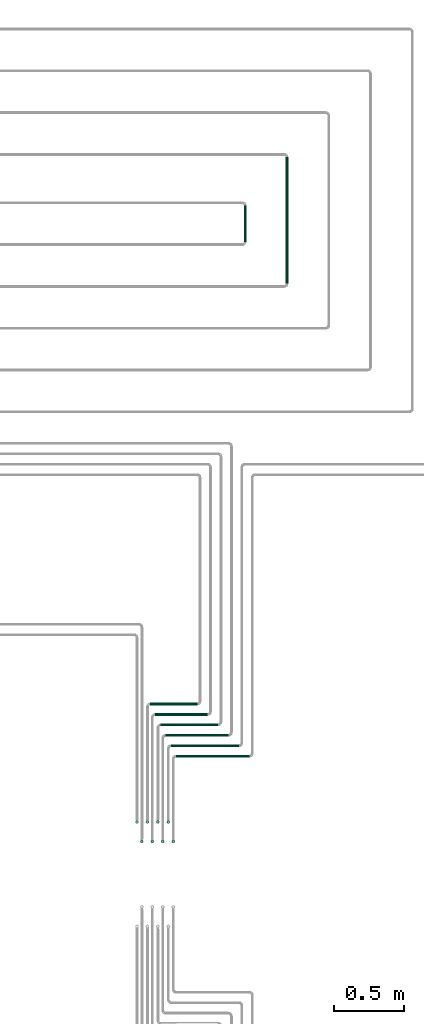
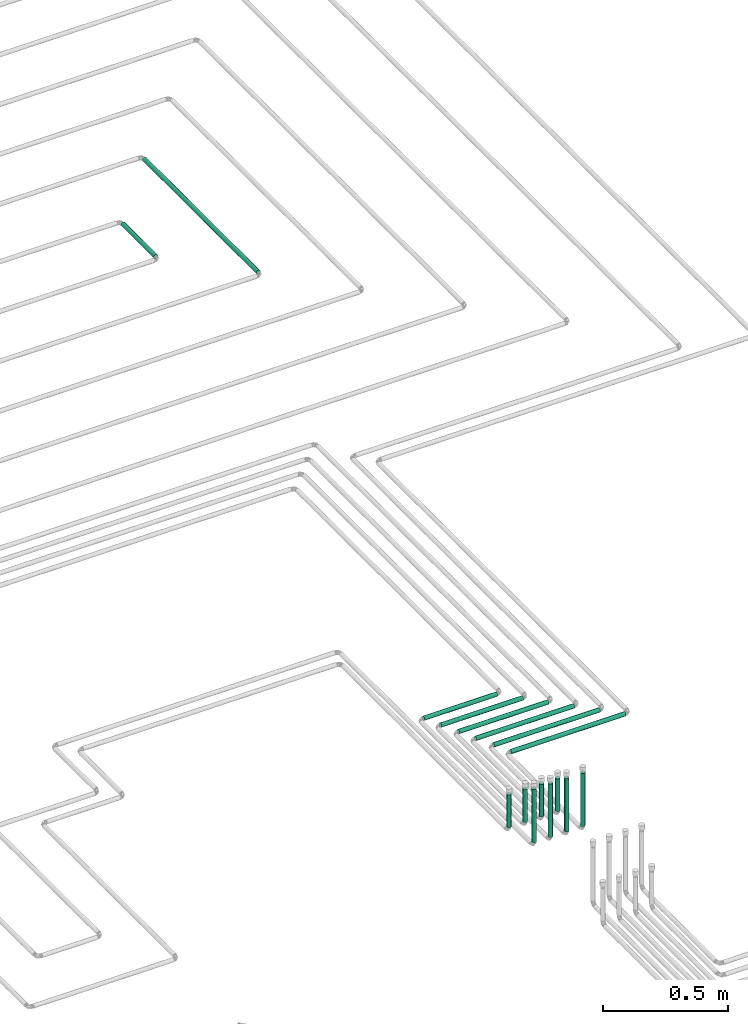
# One storey, part 6 of 12: 16 flow segments.
"""IFC2X3 building model written with IfcOpenShell, lengths in millimetres."""

import ifcopenshell
import ifcopenshell.guid

model = None  # the IFC model being written
_history = None  # IfcOwnerHistory: only IFC2X3 demands one
_inside = {}  # id of a spatial element -> (the spatial element, [elements in it])
_under = {}  # id of a project, library or spatial element -> (it, [spatial elements below it])
_declared = {}  # id of a project -> (the project, [libraries it declares])
_typed = {}  # id of a type object -> (the type object, [elements of that type])
_made_of = {}  # id of a material, layer set ... -> (it, [elements and type objects made of it])


def new_model(schema):
    """Start an empty IFC model of exactly this schema.

    Asked for "IFC4X3", IfcOpenShell would pick the latest addendum, in which some entities
    have other attributes; the version numbers below select the first issue.
    IFC2X3 requires an IfcOwnerHistory on every rooted entity: one is made here for all.
    """
    global model, _history
    if schema == "IFC4X3":
        model = ifcopenshell.file(schema_version=(4, 3, 0, 0))
    else:
        model = ifcopenshell.file(schema=schema)
    _inside.clear()
    _under.clear()
    _declared.clear()
    _typed.clear()
    _made_of.clear()
    _history = None
    if model.schema == "IFC2X3":
        org = make("IfcOrganization", Name="unknown")
        user = make(
            "IfcPersonAndOrganization",
            ThePerson=make("IfcPerson", FamilyName="unknown"),
            TheOrganization=org,
        )
        app = make(
            "IfcApplication",
            ApplicationDeveloper=org,
            Version="unknown",
            ApplicationFullName="unknown",
            ApplicationIdentifier="unknown",
        )
        _history = make(
            "IfcOwnerHistory",
            OwningUser=user,
            OwningApplication=app,
            ChangeAction="ADDED",
            CreationDate=0,
        )
    return model


def make(cls, **values):
    """One entity of the class cls with the attributes given. An attribute that is None is left unset."""
    return model.create_entity(
        cls, **{name: value for name, value in values.items() if value is not None}
    )


def entity(cls, *values):
    """Any entity or typed value of the class cls, its attributes in the order of the schema. None: left unset."""
    e = model.create_entity(cls)
    for i, value in enumerate(values):
        if value is not None:
            e[i] = value
    return e


def rooted(cls, **values):
    """An entity with a GlobalId (a new one), such as an element, a storey or a relation."""
    return make(cls, GlobalId=ifcopenshell.guid.new(), OwnerHistory=_history, **values)


def si_unit(unit_type, name, prefix=None):
    """IfcSIUnit, for example si_unit("LENGTHUNIT", "METRE", prefix="MILLI")."""
    return make("IfcSIUnit", UnitType=unit_type, Prefix=prefix, Name=name)


def converted_unit(unit_type, name, factor, base, dimensions=None, offset=None):
    """IfcConversionBasedUnit, such as the inch: factor (a typed value) times the base unit."""
    return make(
        "IfcConversionBasedUnit"
        if offset is None
        else "IfcConversionBasedUnitWithOffset",
        ConversionOffset=offset,
        Dimensions=None
        if dimensions is None
        else entity("IfcDimensionalExponents", *dimensions),
        UnitType=unit_type,
        Name=name,
        ConversionFactor=make(
            "IfcMeasureWithUnit", ValueComponent=factor, UnitComponent=base
        ),
    )


def derived_unit(unit_type, elements):
    """IfcDerivedUnit: a product of units, each with its exponent."""
    return make(
        "IfcDerivedUnit",
        Elements=[
            make("IfcDerivedUnitElement", Unit=unit, Exponent=power)
            for unit, power in elements
        ],
        UnitType=unit_type,
    )


def assignment(units):
    """IfcUnitAssignment: the units of a project."""
    return None if units is None else make("IfcUnitAssignment", Units=units)


def point(xyz):
    """IfcCartesianPoint."""
    return None if xyz is None else make("IfcCartesianPoint", Coordinates=xyz)


def direction(xyz):
    """IfcDirection."""
    return None if xyz is None else make("IfcDirection", DirectionRatios=xyz)


def frame(location, z_axis=None, x_axis=None):
    """IfcAxis2Placement3D, a coordinate frame: its origin and axes. An axis left out is left unset."""
    return make(
        "IfcAxis2Placement3D",
        Location=point(location),
        Axis=direction(z_axis),
        RefDirection=direction(x_axis),
    )


def frame_2d(location, x_axis=None):
    """IfcAxis2Placement2D, a coordinate frame in the plane: its origin and x axis."""
    return make(
        "IfcAxis2Placement2D", Location=point(location), RefDirection=direction(x_axis)
    )


def origin():
    """The frame at (0, 0, 0) with its axes left unset."""
    return frame((0.0, 0.0, 0.0))


def origin_2d_with_axis():
    """The frame at (0, 0) in the plane with the x axis (1, 0) written out."""
    return frame_2d((0.0, 0.0), x_axis=(1.0, 0.0))


def place(relative_to, where):
    """IfcLocalPlacement: puts the frame where relative to a parent placement (None: the world)."""
    return make(
        "IfcLocalPlacement", PlacementRelTo=relative_to, RelativePlacement=where
    )


def context(
    kind, dimensions, precision=None, world=None, true_north=None, identifier=None
):
    """IfcGeometricRepresentationContext, for example the 3D "Model" context."""
    return make(
        "IfcGeometricRepresentationContext",
        ContextIdentifier=identifier,
        ContextType=kind,
        CoordinateSpaceDimension=dimensions,
        Precision=precision,
        WorldCoordinateSystem=world,
        TrueNorth=true_north,
    )


def subcontext(parent, identifier, kind, view, scale=None):
    """IfcGeometricRepresentationSubContext, for example "Body" below "Model"."""
    return make(
        "IfcGeometricRepresentationSubContext",
        ContextIdentifier=identifier,
        ContextType=kind,
        ParentContext=parent,
        TargetScale=scale,
        TargetView=view,
    )


def project(units=None, contexts=None):
    """IfcProject with its units and contexts."""
    return rooted(
        "IfcProject",
        Name="project",
        RepresentationContexts=contexts,
        UnitsInContext=assignment(units),
    )


def spatial(cls, under=None, at=None, **own):
    """A site, building, storey or space (cls), placed at a placement, below another one or the project."""
    s = rooted(cls, ObjectPlacement=at, **own)
    if under is not None:
        _under.setdefault(under.id(), (under, []))[1].append(s)
    return s


def profile(cls, at=None, kind="AREA", **sizes):
    """A parametric profile (cls). Its sizes go by their IFC names, for example OverallWidth=200.0."""
    return make(cls, ProfileType=kind, Position=at, **sizes)


def circle(**sizes):
    """IfcCircleProfileDef."""
    return profile("IfcCircleProfileDef", **sizes)


def extrude(swept, where, along, depth):
    """IfcExtrudedAreaSolid: the profile swept, set in the frame where, extruded along a direction by depth."""
    return make(
        "IfcExtrudedAreaSolid",
        SweptArea=swept,
        Position=where,
        ExtrudedDirection=direction(along),
        Depth=depth,
    )


def shape(context_of_items, identifier, shape_type, items):
    """IfcShapeRepresentation: the items that make up one representation, for example the "Body"."""
    return make(
        "IfcShapeRepresentation",
        ContextOfItems=context_of_items,
        RepresentationIdentifier=identifier,
        RepresentationType=shape_type,
        Items=items,
    )


def made_of(thing, what):
    """Note that an element or type object is made of a material, layer set ...; save() writes the relation."""
    if what is not None:
        _made_of.setdefault(what.id(), (what, []))[1].append(thing)
    return thing


def type_object(cls, material=None, **own):
    """A type object (cls), such as IfcWallType, which elements share."""
    return made_of(rooted(cls, **own), material)


def element(
    cls,
    number,
    at=None,
    inside=None,
    cuts=None,
    type_object=None,
    material=None,
    context=None,
    identifier="Body",
    shape_type=None,
    held_by="IfcProductDefinitionShape",
    body=None,
    shapes=None,
    **own,
):
    """One element of the class cls, such as IfcWall. Its Tag is "e" and its number.

    at: its placement. inside: the storey or other place that contains it. cuts: it is an
    opening in that element (IfcRelVoidsElement). A single representation is given by context,
    identifier, shape_type and body (its items); several are given by shapes. held_by: the class
    of the entity that holds the representations. save() writes the other relations.
    """
    e = rooted(cls, Tag="e%d" % number, ObjectPlacement=at, **own)
    if body is not None:
        shapes = [shape(context, identifier, shape_type, body)]
    if shapes is not None:
        e.Representation = make(held_by, Representations=shapes)
    if inside is not None:
        _inside.setdefault(inside.id(), (inside, []))[1].append(e)
    if cuts is not None:
        rooted(
            "IfcRelVoidsElement", RelatingBuildingElement=cuts, RelatedOpeningElement=e
        )
    if type_object is not None:
        _typed.setdefault(type_object.id(), (type_object, []))[1].append(e)
    return made_of(e, material)


def aggregate(whole, parts):
    """IfcRelAggregates: a whole, such as a stair, and the parts it consists of."""
    return rooted("IfcRelAggregates", RelatingObject=whole, RelatedObjects=parts)


def save(model, path):
    """Write the relations noted so far, then the file.

    IfcRelAggregates (storeys below a building ...), IfcRelContainedInSpatialStructure (elements
    in a storey), IfcRelDefinesByType, IfcRelAssociatesMaterial and IfcRelDeclares: one each for
    every whole, place, type object, material and project.
    """
    for whole, parts in _under.values():
        aggregate(whole, parts)
    for where, things in _inside.values():
        rooted(
            "IfcRelContainedInSpatialStructure",
            RelatedElements=things,
            RelatingStructure=where,
        )
    for kind, things in _typed.values():
        rooted("IfcRelDefinesByType", RelatedObjects=things, RelatingType=kind)
    for what, things in _made_of.values():
        rooted("IfcRelAssociatesMaterial", RelatedObjects=things, RelatingMaterial=what)
    for by, libraries in _declared.values():
        rooted("IfcRelDeclares", RelatingContext=by, RelatedDefinitions=libraries)
    model.write(path)


model = new_model("IFC2X3")

# Units and contexts
model_context = context("Model", 3, precision=0.01, world=origin(), true_north=direction((6.12303176911189e-17, 1.0)))
body_context = subcontext(model_context, "Body", "Model", "MODEL_VIEW")
ifc_project = project(units=[si_unit("LENGTHUNIT", "METRE", prefix="MILLI"), si_unit("AREAUNIT", "SQUARE_METRE"), si_unit("VOLUMEUNIT", "CUBIC_METRE"), converted_unit("PLANEANGLEUNIT", "DEGREE", entity("IfcRatioMeasure", 0.0174532925199433), si_unit("PLANEANGLEUNIT", "RADIAN"), dimensions=[0, 0, 0, 0, 0, 0, 0]), si_unit("MASSUNIT", "GRAM", prefix="KILO"), derived_unit("MASSDENSITYUNIT", [(si_unit("MASSUNIT", "GRAM", prefix="KILO"), 1), (si_unit("LENGTHUNIT", "METRE"), -3)]), si_unit("TIMEUNIT", "SECOND"), si_unit("FREQUENCYUNIT", "HERTZ"), si_unit("THERMODYNAMICTEMPERATUREUNIT", "DEGREE_CELSIUS"), derived_unit("THERMALTRANSMITTANCEUNIT", [(si_unit("MASSUNIT", "GRAM", prefix="KILO"), 1), (si_unit("THERMODYNAMICTEMPERATUREUNIT", "KELVIN"), -1), (si_unit("TIMEUNIT", "SECOND"), -3)]), derived_unit("VOLUMETRICFLOWRATEUNIT", [(si_unit("LENGTHUNIT", "METRE"), 3), (si_unit("TIMEUNIT", "SECOND"), -1)]), si_unit("ELECTRICCURRENTUNIT", "AMPERE"), si_unit("ELECTRICVOLTAGEUNIT", "VOLT"), si_unit("POWERUNIT", "WATT"), si_unit("FORCEUNIT", "NEWTON", prefix="KILO"), si_unit("ILLUMINANCEUNIT", "LUX"), si_unit("LUMINOUSFLUXUNIT", "LUMEN"), si_unit("LUMINOUSINTENSITYUNIT", "CANDELA"), derived_unit("USERDEFINED", [(si_unit("MASSUNIT", "GRAM", prefix="KILO"), -1), (si_unit("LENGTHUNIT", "METRE"), -2), (si_unit("TIMEUNIT", "SECOND"), 3), (si_unit("LUMINOUSFLUXUNIT", "LUMEN"), 1)]), derived_unit("LINEARVELOCITYUNIT", [(si_unit("LENGTHUNIT", "METRE"), 1), (si_unit("TIMEUNIT", "SECOND"), -1)]), si_unit("PRESSUREUNIT", "PASCAL"), derived_unit("USERDEFINED", [(si_unit("LENGTHUNIT", "METRE"), -2), (si_unit("MASSUNIT", "GRAM", prefix="KILO"), 1), (si_unit("TIMEUNIT", "SECOND"), -2)])], contexts=[model_context])

# Site, building, storey
site_placement = place(None, origin())
site = spatial("IfcSite", under=ifc_project, at=site_placement, CompositionType="ELEMENT")
building_placement = place(site_placement, origin())
building = spatial("IfcBuilding", under=site, at=building_placement, CompositionType="ELEMENT")
storey_placement = place(building_placement, frame((0.0, 0.0, 4000.0)))
storey = spatial("IfcBuildingStorey", under=building, at=storey_placement, Name="01 Level", CompositionType="ELEMENT", Elevation=4000.0)

# Flow segments
pipe_segment_type = type_object("IfcPipeSegmentType", PredefinedType="NOTDEFINED")
flow_segment_1_placement = place(storey_placement, frame((26841.501809184, -64590.4944566176, -81.5952722359198)))
element("IfcFlowSegment", 1, at=flow_segment_1_placement, inside=storey, type_object=pipe_segment_type, context=body_context, shape_type="SweptSolid", body=[
    extrude(circle(Radius=10.0, at=origin_2d_with_axis()), frame((11.595272235931, 0.0, 11.5952722359158), z_axis=(0.0, 1.0, 0.0), x_axis=(1.0, 0.0, 0.0)), (0.0, 0.0, 1.0), 907.858932130948),
])
flow_segment_2_placement = place(storey_placement, frame((26541.501809184, -64290.4944566176, -81.5952722359266)))
element("IfcFlowSegment", 2, at=flow_segment_2_placement, inside=storey, type_object=pipe_segment_type, context=body_context, shape_type="SweptSolid", body=[
    extrude(circle(Radius=10.0, at=origin_2d_with_axis()), frame((11.5952722359266, 0.0, 11.5952722359158), z_axis=(0.0, 1.0, 0.0), x_axis=(1.0, 0.0, 0.0)), (0.0, 0.0, 1.0), 260.000000000019),
])
flow_segment_3_placement = place(storey_placement, frame((25981.0369719708, -67845.3348573759, -81.5952722359302)))
element("IfcFlowSegment", 3, at=flow_segment_3_placement, inside=storey, type_object=pipe_segment_type, context=body_context, shape_type="SweptSolid", body=[
    extrude(circle(Radius=10.0, at=origin_2d_with_axis()), frame((0.0, 11.5952722359483, 11.5952722359158), z_axis=(1.0, 0.0, 0.0), x_axis=(0.0, -1.0, 0.0)), (0.0, 0.0, 1.0), 452.648577476757),
])
flow_segment_4_placement = place(storey_placement, frame((25946.0369719708, -67770.3348573759, -81.595272235932)))
element("IfcFlowSegment", 4, at=flow_segment_4_placement, inside=storey, type_object=pipe_segment_type, context=body_context, shape_type="SweptSolid", body=[
    extrude(circle(Radius=10.0, at=origin_2d_with_axis()), frame((0.0, 11.5952722359483, 11.5952722359158), z_axis=(1.0, 0.0, 0.0), x_axis=(0.0, -1.0, 0.0)), (0.0, 0.0, 1.0), 412.648577476762),
])
flow_segment_5_placement = place(storey_placement, frame((25906.0369719708, -67695.3348573759, -81.5952722359311)))
element("IfcFlowSegment", 5, at=flow_segment_5_placement, inside=storey, type_object=pipe_segment_type, context=body_context, shape_type="SweptSolid", body=[
    extrude(circle(Radius=10.0, at=origin_2d_with_axis()), frame((0.0, 11.5952722359483, 11.5952722359158), z_axis=(1.0, 0.0, 0.0), x_axis=(0.0, -1.0, 0.0)), (0.0, 0.0, 1.0), 377.648577476765),
])
flow_segment_6_placement = place(storey_placement, frame((25871.0369719708, -67620.3348573759, -81.5952722359302)))
element("IfcFlowSegment", 6, at=flow_segment_6_placement, inside=storey, type_object=pipe_segment_type, context=body_context, shape_type="SweptSolid", body=[
    extrude(circle(Radius=10.0, at=origin_2d_with_axis()), frame((0.0, 11.5952722359483, 11.5952722359158), z_axis=(1.0, 0.0, 0.0), x_axis=(0.0, -1.0, 0.0)), (0.0, 0.0, 1.0), 337.64857747677),
])
flow_segment_7_placement = place(storey_placement, frame((26056.0369719708, -67995.3348573759, -81.595272235932)))
element("IfcFlowSegment", 7, at=flow_segment_7_placement, inside=storey, type_object=pipe_segment_type, context=body_context, shape_type="SweptSolid", body=[
    extrude(circle(Radius=10.0, at=origin_2d_with_axis()), frame((0.0, 11.5952722359569, 11.5952722359158), z_axis=(1.0, 0.0, 0.0), x_axis=(0.0, -1.0, 0.0)), (0.0, 0.0, 1.0), 527.648577476736),
])
flow_segment_8_placement = place(storey_placement, frame((26021.0369719708, -67920.3348573759, -81.5952722359311)))
element("IfcFlowSegment", 8, at=flow_segment_8_placement, inside=storey, type_object=pipe_segment_type, context=body_context, shape_type="SweptSolid", body=[
    extrude(circle(Radius=10.0, at=origin_2d_with_axis()), frame((0.0, 11.5952722359483, 11.5952722359158), z_axis=(1.0, 0.0, 0.0), x_axis=(0.0, -1.0, 0.0)), (0.0, 0.0, 1.0), 487.648577476745),
])
flow_segment_9_placement = place(storey_placement, frame((25764.4416997349, -68467.8348573759, -50.0)))
element("IfcFlowSegment", 9, at=flow_segment_9_placement, inside=storey, type_object=pipe_segment_type, context=body_context, shape_type="SweptSolid", body=[
    extrude(circle(Radius=10.0, at=origin_2d_with_axis()), frame((11.595272235918, 11.5952722359136, 0.0)), (0.0, 0.0, 1.0), 160.000000000009),
])
flow_segment_10_placement = place(storey_placement, frame((25799.4416997349, -68607.8348573758, -50.0)))
element("IfcFlowSegment", 10, at=flow_segment_10_placement, inside=storey, type_object=pipe_segment_type, context=body_context, shape_type="SweptSolid", body=[
    extrude(circle(Radius=10.0, at=origin_2d_with_axis()), frame((11.595272235918, 11.5952722359136, 0.0)), (0.0, 0.0, 1.0), 260.000000000014),
])
flow_segment_11_placement = place(storey_placement, frame((25839.4416997349, -68467.8348573759, -50.0)))
element("IfcFlowSegment", 11, at=flow_segment_11_placement, inside=storey, type_object=pipe_segment_type, context=body_context, shape_type="SweptSolid", body=[
    extrude(circle(Radius=10.0, at=origin_2d_with_axis()), frame((11.595272235918, 11.5952722359136, 0.0)), (0.0, 0.0, 1.0), 160.000000000014),
])
flow_segment_12_placement = place(storey_placement, frame((25874.4416997349, -68607.8348573758, -50.0)))
element("IfcFlowSegment", 12, at=flow_segment_12_placement, inside=storey, type_object=pipe_segment_type, context=body_context, shape_type="SweptSolid", body=[
    extrude(circle(Radius=10.0, at=origin_2d_with_axis()), frame((11.595272235918, 11.5952722359136, 0.0)), (0.0, 0.0, 1.0), 260.000000000015),
])
flow_segment_13_placement = place(storey_placement, frame((25914.4416997349, -68467.8348573759, -50.0)))
element("IfcFlowSegment", 13, at=flow_segment_13_placement, inside=storey, type_object=pipe_segment_type, context=body_context, shape_type="SweptSolid", body=[
    extrude(circle(Radius=10.0, at=origin_2d_with_axis()), frame((11.595272235918, 11.5952722359136, 0.0)), (0.0, 0.0, 1.0), 160.000000000016),
])
flow_segment_14_placement = place(storey_placement, frame((25949.4416997349, -68607.8348573758, -50.0)))
element("IfcFlowSegment", 14, at=flow_segment_14_placement, inside=storey, type_object=pipe_segment_type, context=body_context, shape_type="SweptSolid", body=[
    extrude(circle(Radius=10.0, at=origin_2d_with_axis()), frame((11.595272235918, 11.5952722359136, 0.0)), (0.0, 0.0, 1.0), 260.000000000014),
])
flow_segment_15_placement = place(storey_placement, frame((25989.4416997349, -68467.8348573759, -50.0)))
element("IfcFlowSegment", 15, at=flow_segment_15_placement, inside=storey, type_object=pipe_segment_type, context=body_context, shape_type="SweptSolid", body=[
    extrude(circle(Radius=10.0, at=origin_2d_with_axis()), frame((11.595272235918, 11.5952722359136, 0.0)), (0.0, 0.0, 1.0), 160.000000000015),
])
flow_segment_16_placement = place(storey_placement, frame((26024.4416997349, -68607.8348573758, -50.0)))
element("IfcFlowSegment", 16, at=flow_segment_16_placement, inside=storey, type_object=pipe_segment_type, context=body_context, shape_type="SweptSolid", body=[
    extrude(circle(Radius=10.0, at=origin_2d_with_axis()), frame((11.595272235918, 11.5952722359136, 0.0)), (0.0, 0.0, 1.0), 260.000000000016),
])

save(model, "model.ifc")
